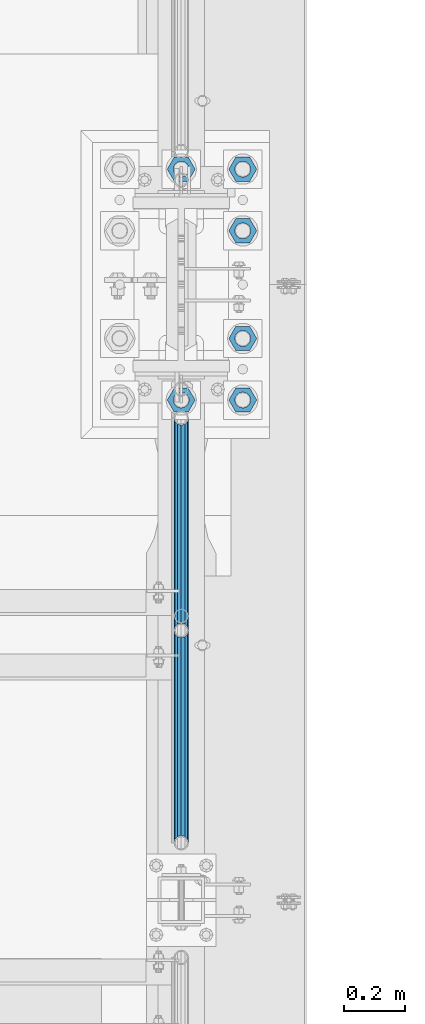
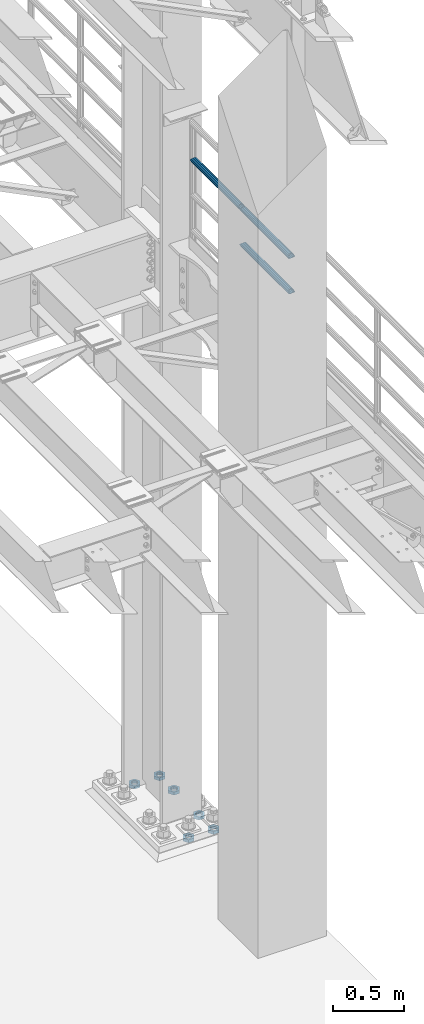
# One storey, part 1337 of 1876: 9 beams, 2 elements without a shape of their own.
"""IFC2X3 building model written with IfcOpenShell, lengths in millimetres."""

from ifc_helpers import new_model, si_unit, frame, origin_with_axes, place, context, subcontext, project, spatial, faceted_brep, material, type_object, element, aggregate, save


model = new_model("IFC2X3")

# Units and contexts
model_context = context("Model", 3, precision=1e-05, world=origin_with_axes())
body_context = subcontext(model_context, "Body", "Model", "MODEL_VIEW")
ifc_project = project(units=[si_unit("LENGTHUNIT", "METRE", prefix="MILLI"), si_unit("AREAUNIT", "SQUARE_METRE"), si_unit("VOLUMEUNIT", "CUBIC_METRE"), si_unit("MASSUNIT", "GRAM", prefix="KILO"), si_unit("TIMEUNIT", "SECOND"), si_unit("PLANEANGLEUNIT", "RADIAN"), si_unit("SOLIDANGLEUNIT", "STERADIAN"), si_unit("THERMODYNAMICTEMPERATUREUNIT", "DEGREE_CELSIUS"), si_unit("LUMINOUSINTENSITYUNIT", "LUMEN")], contexts=[model_context])

# Site, building, storey
site_placement = place(None, origin_with_axes())
site = spatial("IfcSite", under=ifc_project, at=site_placement, CompositionType="ELEMENT")
building_placement = place(site_placement, origin_with_axes())
building = spatial("IfcBuilding", under=site, at=building_placement, Name="Undefined", CompositionType="ELEMENT")
storey_placement = place(building_placement, origin_with_axes())
storey = spatial("IfcBuildingStorey", under=building, at=storey_placement, Name="Undefined", CompositionType="ELEMENT", Elevation=0.0)

# Assembly, beams
assembly_1_placement = place(storey_placement, origin_with_axes())
assembly_1 = element("IfcElementAssembly", 1, at=assembly_1_placement, inside=storey, Name="RAIL", AssemblyPlace="NOTDEFINED", PredefinedType="RIGID_FRAME")
ifc_material_1 = material()
beam_type_1 = type_object("IfcBeamType", Name="PIPE1-1/2SCH40", PredefinedType="NOTDEFINED")
beam_1_placement = place(assembly_1_placement, frame((7620.00000000007, 6478.5698316807, 5597.53091229414), z_axis=(0.0, 7.91400000045761e-06, -0.999999999968684), x_axis=(0.0, -0.999999999968684, -7.91400000071008e-06)))
beam_1 = element("IfcBeam", 2, at=beam_1_placement, type_object=beam_type_1, material=ifc_material_1, Name="RAIL", ObjectType="PIPE1-1/2SCH40", context=body_context, shape_type="Brep", body=[
    faceted_brep([(0.0, 24.1299999999992, 0.0), (12.0648982924813, 20.8971929933186, -12.0650000000005), (12.065101708381, 20.8971929933186, 12.0650000000005), (12.065101708381, -20.8971929933186, 12.0650000000005), (12.0648982924813, -20.8971929933186, -12.0650000000005), (0.0, -24.1299999999992, 0.0), (20.897369157401, -12.0649999999996, 20.8971929933205), (20.8973267454676, -12.0649999999277, 15.8661214312533), (15.2546577467156, -17.7076214311801, 10.223500000001), (12.5151929933249, -20.4470000000001, 0.0), (15.2544853785057, -17.7076214311801, -10.2235000000001), (20.8970592426604, -12.0649999999277, -15.8661214312533), (20.8970168307269, -12.0649999999996, -20.8971929933195), (24.1298276326506, 0.0, -20.447000000001), (24.1297965849608, 0.0, -24.130000000001), (21.390472156676, -10.2235000000001, -17.7076214311819), (21.3904721567151, 10.2235000000001, -17.7076214311819), (20.8970592426604, 12.0650000000714, -15.8661214311096), (20.8970168307269, 12.0649999999996, -20.8971929933195), (15.2544853786503, 17.7076214311801, -10.2235000000001), (12.5151929933249, 20.4470000000001, 0.0), (15.2546577468602, 17.7076214311801, 10.223500000001), (20.8973267454676, 12.0650000000714, 15.8661214311096), (20.897369157401, 12.0649999999996, 20.8971929933205), (21.3907707072121, 10.2235000000001, 17.7076214311819), (24.1301723690713, 7.18500814400613e-11, 20.447000000001), (24.1302034167611, 7.18500814400613e-11, 24.1300000000019), (21.390770707173, -10.2235000000001, 17.7076214311819), (701.33983170571, 24.1300000000001, -1.45519152283669e-11), (689.27472999733, 20.8971929933186, -12.0650000000151), (680.442462548309, 12.0649999999996, -20.8971929933323), (701.33983170571, -24.1299999999283, -1.45519152283669e-11), (689.27472999733, -20.8971929933186, -12.0650000000151), (689.27493341323, -20.8971929933186, 12.0649999999878), (680.442814874983, -12.0649999999996, 20.8971929933068), (680.442462548309, -12.0649999999996, -20.8971929933323), (677.20962828895, 0.0, -24.1300000000147), (679.949060998498, 10.2235000000001, -17.7076214311946), (677.20965933664, 0.0, -20.4470000000147), (680.442504960242, 12.0650000000714, -15.8661214311223), (680.442504960242, -12.0649999999277, -15.866121431266), (679.949060998536, -10.2235000000001, -17.7076214311946), (686.085173958994, -17.7076214311801, -10.2235000000137), (688.824638712016, -20.4470000000001, -1.36424205265939e-11), (686.085346327204, -17.7076214311801, 10.2234999999873), (680.44277246305, -12.0649999999277, 15.8661214312397), (679.949359549034, -10.2235000000001, 17.7076214311674), (677.210004073059, 2.72848410531878e-12, 20.4469999999883), (677.210035120749, 2.72848410531878e-12, 24.1299999999883), (680.442814874983, 12.0649999999996, 20.8971929933068), (689.27493341323, 20.8971929933186, 12.0649999999878), (680.44277246305, 12.0650000000714, 15.866121431096), (686.085346327061, 17.7076214311801, 10.2234999999873), (688.824638711873, 20.4470000000001, -1.36424205265939e-11), (686.085173958852, 17.7076214311801, -10.2235000000137), (679.949359548996, 10.2235000000001, 17.7076214311674)], [[[0, 1, 2]], [[3, 4, 5]], [[6, 7, 8, 9, 10, 11, 12, 4, 3]], [[13, 14, 12, 11, 15]], [[16, 17, 18, 14, 13]], [[2, 1, 18, 17, 19, 20, 21, 22, 23]], [[23, 22, 24, 25, 26]], [[26, 25, 27, 7, 6]], [[1, 0, 28, 29]], [[18, 1, 29, 30]], [[31, 32, 33]], [[6, 3, 33, 34]], [[3, 5, 31, 33]], [[5, 4, 32, 31]], [[4, 12, 35, 32]], [[12, 14, 36, 35]], [[14, 18, 30, 36]], [[37, 38, 36, 30, 39]], [[40, 35, 36, 38, 41]], [[33, 32, 35, 40, 42, 43, 44, 45, 34]], [[34, 45, 46, 47, 48]], [[26, 6, 34, 48]], [[2, 23, 49, 50]], [[23, 26, 48, 49]], [[0, 2, 50, 28]], [[28, 50, 29]], [[49, 51, 52, 53, 54, 39, 30, 29, 50]], [[48, 47, 55, 51, 49]], [[25, 24, 55, 47]], [[55, 24, 22, 21, 52, 51]], [[21, 20, 53, 52]], [[20, 19, 54, 53]], [[19, 17, 16, 37, 39, 54]], [[16, 13, 38, 37]], [[13, 15, 41, 38]], [[41, 15, 11, 10, 42, 40]], [[10, 9, 43, 42]], [[9, 8, 44, 43]], [[8, 7, 27, 46, 45, 44]], [[27, 25, 47, 46]]]),
])
beam_2_placement = place(assembly_1_placement, frame((7620.00000000067, 7179.9096633614, 5902.3368245991), z_axis=(0.0, 7.91400000045761e-06, -0.999999999968684), x_axis=(0.0, -0.999999999968684, -7.91400000071008e-06)))
beam_2 = element("IfcBeam", 3, at=beam_2_placement, type_object=beam_type_1, material=ifc_material_1, Name="RAIL", ObjectType="PIPE1-1/2SCH40", context=body_context, shape_type="Brep", body=[
    faceted_brep([(0.0, 24.1299999999992, 0.0), (12.0648982924813, 20.8971929933186, -12.0650000000005), (12.065101708381, 20.8971929933186, 12.0650000000005), (12.065101708381, -20.8971929933186, 12.0650000000005), (12.0648982924813, -20.8971929933186, -12.0650000000005), (0.0, -24.1299999999992, 0.0), (20.897369157401, -12.0649999999996, 20.8971929933205), (20.8973267454676, -12.0649999999277, 15.8661214312533), (15.2546577467156, -17.7076214311801, 10.223500000001), (12.5151929933249, -20.4470000000001, 0.0), (15.2544853785057, -17.7076214311801, -10.2235000000001), (20.8970592426604, -12.0649999999277, -15.8661214312533), (20.8970168307269, -12.0649999999996, -20.8971929933195), (24.1298276326506, 0.0, -20.447000000001), (24.1297965849608, 0.0, -24.130000000001), (21.390472156676, -10.2235000000001, -17.7076214311819), (21.3904721567151, 10.2235000000001, -17.7076214311819), (20.8970592426604, 12.0650000000714, -15.8661214311096), (20.8970168307269, 12.0649999999996, -20.8971929933195), (15.2544853786503, 17.7076214311801, -10.2235000000001), (12.5151929933249, 20.4470000000001, 0.0), (15.2546577468602, 17.7076214311801, 10.223500000001), (20.8973267454676, 12.0650000000714, 15.8661214311096), (20.897369157401, 12.0649999999996, 20.8971929933205), (21.3907707072121, 10.2235000000001, 17.7076214311819), (24.1301723690713, 7.18500814400613e-11, 20.447000000001), (24.1302034167611, 7.18500814400613e-11, 24.1300000000019), (21.390770707173, -10.2235000000001, 17.7076214311819), (701.33983170571, 24.1300000000001, -1.45519152283669e-11), (689.27472999733, 20.8971929933186, -12.0650000000151), (680.442462548309, 12.0649999999996, -20.8971929933323), (701.33983170571, -24.1299999999283, -1.45519152283669e-11), (689.27472999733, -20.8971929933186, -12.0650000000151), (689.27493341323, -20.8971929933186, 12.0649999999878), (680.442814874983, -12.0649999999996, 20.8971929933068), (680.442462548309, -12.0649999999996, -20.8971929933323), (677.20962828895, 0.0, -24.1300000000147), (679.949060998498, 10.2235000000001, -17.7076214311946), (677.20965933664, 0.0, -20.4470000000147), (680.442504960242, 12.0650000000714, -15.8661214311223), (680.442504960242, -12.0649999999277, -15.866121431266), (679.949060998536, -10.2235000000001, -17.7076214311946), (686.085173958994, -17.7076214311801, -10.2235000000137), (688.824638712016, -20.4470000000001, -1.36424205265939e-11), (686.085346327204, -17.7076214311801, 10.2234999999873), (680.44277246305, -12.0649999999277, 15.8661214312397), (679.949359549034, -10.2235000000001, 17.7076214311674), (677.210004073059, 2.72848410531878e-12, 20.4469999999883), (677.210035120749, 2.72848410531878e-12, 24.1299999999883), (680.442814874983, 12.0649999999996, 20.8971929933068), (689.27493341323, 20.8971929933186, 12.0649999999878), (680.44277246305, 12.0650000000714, 15.866121431096), (686.085346327061, 17.7076214311801, 10.2234999999873), (688.824638711873, 20.4470000000001, -1.36424205265939e-11), (686.085173958852, 17.7076214311801, -10.2235000000137), (679.949359548996, 10.2235000000001, 17.7076214311674)], [[[0, 1, 2]], [[3, 4, 5]], [[6, 7, 8, 9, 10, 11, 12, 4, 3]], [[13, 14, 12, 11, 15]], [[16, 17, 18, 14, 13]], [[2, 1, 18, 17, 19, 20, 21, 22, 23]], [[23, 22, 24, 25, 26]], [[26, 25, 27, 7, 6]], [[1, 0, 28, 29]], [[18, 1, 29, 30]], [[31, 32, 33]], [[6, 3, 33, 34]], [[3, 5, 31, 33]], [[5, 4, 32, 31]], [[4, 12, 35, 32]], [[12, 14, 36, 35]], [[14, 18, 30, 36]], [[37, 38, 36, 30, 39]], [[40, 35, 36, 38, 41]], [[33, 32, 35, 40, 42, 43, 44, 45, 34]], [[34, 45, 46, 47, 48]], [[26, 6, 34, 48]], [[2, 23, 49, 50]], [[23, 26, 48, 49]], [[0, 2, 50, 28]], [[28, 50, 29]], [[49, 51, 52, 53, 54, 39, 30, 29, 50]], [[48, 47, 55, 51, 49]], [[25, 24, 55, 47]], [[55, 24, 22, 21, 52, 51]], [[21, 20, 53, 52]], [[20, 19, 54, 53]], [[19, 17, 16, 37, 39, 54]], [[16, 13, 38, 37]], [[13, 15, 41, 38]], [[41, 15, 11, 10, 42, 40]], [[10, 9, 43, 42]], [[9, 8, 44, 43]], [[8, 7, 27, 46, 45, 44]], [[27, 25, 47, 46]]]),
])
beam_3_placement = place(assembly_1_placement, frame((7620.00000000007, 6478.5698316807, 5902.33091229485), z_axis=(0.0, 7.91400000045761e-06, -0.999999999968684), x_axis=(0.0, -0.999999999968684, -7.91400000071008e-06)))
beam_3 = element("IfcBeam", 4, at=beam_3_placement, type_object=beam_type_1, material=ifc_material_1, Name="RAIL", ObjectType="PIPE1-1/2SCH40", context=body_context, shape_type="Brep", body=[
    faceted_brep([(0.0, 24.1299999999992, 0.0), (12.0648982924813, 20.8971929933186, -12.0650000000005), (12.065101708381, 20.8971929933186, 12.0650000000005), (12.065101708381, -20.8971929933186, 12.0650000000005), (12.0648982924813, -20.8971929933186, -12.0650000000005), (0.0, -24.1299999999992, 0.0), (20.897369157401, -12.0649999999996, 20.8971929933205), (20.8973267454676, -12.0649999999277, 15.8661214312533), (15.2546577467156, -17.7076214311801, 10.223500000001), (12.5151929933249, -20.4470000000001, 0.0), (15.2544853785057, -17.7076214311801, -10.2235000000001), (20.8970592426604, -12.0649999999277, -15.8661214312533), (20.8970168307269, -12.0649999999996, -20.8971929933195), (24.1298276326506, 0.0, -20.447000000001), (24.1297965849608, 0.0, -24.130000000001), (21.390472156676, -10.2235000000001, -17.7076214311819), (21.3904721567151, 10.2235000000001, -17.7076214311819), (20.8970592426604, 12.0650000000714, -15.8661214311096), (20.8970168307269, 12.0649999999996, -20.8971929933195), (15.2544853786503, 17.7076214311801, -10.2235000000001), (12.5151929933249, 20.4470000000001, 0.0), (15.2546577468602, 17.7076214311801, 10.223500000001), (20.8973267454676, 12.0650000000714, 15.8661214311096), (20.897369157401, 12.0649999999996, 20.8971929933205), (21.3907707072121, 10.2235000000001, 17.7076214311819), (24.1301723690713, 7.18500814400613e-11, 20.447000000001), (24.1302034167611, 7.18500814400613e-11, 24.1300000000019), (21.390770707173, -10.2235000000001, 17.7076214311819), (701.33983170571, 24.1300000000001, -1.45519152283669e-11), (689.27472999733, 20.8971929933186, -12.0650000000151), (680.442462548309, 12.0649999999996, -20.8971929933323), (701.33983170571, -24.1299999999283, -1.45519152283669e-11), (689.27472999733, -20.8971929933186, -12.0650000000151), (689.27493341323, -20.8971929933186, 12.0649999999878), (680.442814874983, -12.0649999999996, 20.8971929933068), (680.442462548309, -12.0649999999996, -20.8971929933323), (677.20962828895, 0.0, -24.1300000000147), (679.949060998498, 10.2235000000001, -17.7076214311946), (677.20965933664, 0.0, -20.4470000000147), (680.442504960242, 12.0650000000714, -15.8661214311223), (680.442504960242, -12.0649999999277, -15.866121431266), (679.949060998536, -10.2235000000001, -17.7076214311946), (686.085173958994, -17.7076214311801, -10.2235000000137), (688.824638712016, -20.4470000000001, -1.36424205265939e-11), (686.085346327204, -17.7076214311801, 10.2234999999873), (680.44277246305, -12.0649999999277, 15.8661214312397), (679.949359549034, -10.2235000000001, 17.7076214311674), (677.210004073059, 2.72848410531878e-12, 20.4469999999883), (677.210035120749, 2.72848410531878e-12, 24.1299999999883), (680.442814874983, 12.0649999999996, 20.8971929933068), (689.27493341323, 20.8971929933186, 12.0649999999878), (680.44277246305, 12.0650000000714, 15.866121431096), (686.085346327061, 17.7076214311801, 10.2234999999873), (688.824638711873, 20.4470000000001, -1.36424205265939e-11), (686.085173958852, 17.7076214311801, -10.2235000000137), (679.949359548996, 10.2235000000001, 17.7076214311674)], [[[0, 1, 2]], [[3, 4, 5]], [[6, 7, 8, 9, 10, 11, 12, 4, 3]], [[13, 14, 12, 11, 15]], [[16, 17, 18, 14, 13]], [[2, 1, 18, 17, 19, 20, 21, 22, 23]], [[23, 22, 24, 25, 26]], [[26, 25, 27, 7, 6]], [[1, 0, 28, 29]], [[18, 1, 29, 30]], [[31, 32, 33]], [[6, 3, 33, 34]], [[3, 5, 31, 33]], [[5, 4, 32, 31]], [[4, 12, 35, 32]], [[12, 14, 36, 35]], [[14, 18, 30, 36]], [[37, 38, 36, 30, 39]], [[40, 35, 36, 38, 41]], [[33, 32, 35, 40, 42, 43, 44, 45, 34]], [[34, 45, 46, 47, 48]], [[26, 6, 34, 48]], [[2, 23, 49, 50]], [[23, 26, 48, 49]], [[0, 2, 50, 28]], [[28, 50, 29]], [[49, 51, 52, 53, 54, 39, 30, 29, 50]], [[48, 47, 55, 51, 49]], [[25, 24, 55, 47]], [[55, 24, 22, 21, 52, 51]], [[21, 20, 53, 52]], [[20, 19, 54, 53]], [[19, 17, 16, 37, 39, 54]], [[16, 13, 38, 37]], [[13, 15, 41, 38]], [[41, 15, 11, 10, 42, 40]], [[10, 9, 43, 42]], [[9, 8, 44, 43]], [[8, 7, 27, 46, 45, 44]], [[27, 25, 47, 46]]]),
])
aggregate(assembly_1, [beam_1, beam_2, beam_3])

assembly_2_placement = place(storey_placement, origin_with_axes())
assembly_2 = element("IfcElementAssembly", 5, at=assembly_2_placement, inside=storey, Name="TEMPLATE", AssemblyPlace="NOTDEFINED", PredefinedType="RIGID_FRAME")
ifc_material_2 = material(Name="STEEL/A563")
beam_type_2 = type_object("IfcBeamType", Name="2_DIA. HALF_NUT", PredefinedType="NOTDEFINED")
beam_4_placement = place(assembly_2_placement, frame((7620.0, 8000.99999847412, 33.3375), z_axis=(0.0, -1.0, 0.0), x_axis=(0.0, 0.0, -1.0)))
beam_4 = element("IfcBeam", 6, at=beam_4_placement, type_object=beam_type_2, material=ifc_material_2, Name="NUT", ObjectType="2_DIA. HALF_NUT", context=body_context, shape_type="Brep", body=[
    faceted_brep([(0.0, -46.0369987487793, 9.09494701772928e-13), (0.0, -23.0184993743896, -39.869213104248), (25.4, -23.0184993743896, -39.869213104248), (25.4, -46.0369987487793, 9.09494701772928e-13), (0.0, 23.0184993743896, -39.869213104248), (25.4, 23.0184993743896, -39.869213104248), (0.0, 46.0369987487793, -9.09494701772928e-13), (25.4, 46.0369987487793, -9.09494701772928e-13), (0.0, 23.0184993743896, 39.869213104248), (25.4, 23.0184993743896, 39.869213104248), (0.0, -23.0184993743896, 39.869213104248), (25.4, -23.0184993743896, 39.869213104248), (0.0, 0.0, 26.1940002441406), (0.0, 11.3650617044514, 23.5999013092769), (25.4, 11.3650617044514, 23.5999013092769), (25.4, 0.0, 26.1940002441406), (0.0, 20.4791109456437, 16.3316083006703), (25.4, 20.4791109456437, 16.3316083006703), (0.0, 25.5370200498346, 5.82867859874477), (25.4, 25.5370200498346, 5.82867859874477), (0.0, 25.5370200498346, -5.82867859874477), (25.4, 25.5370200498346, -5.82867859874477), (0.0, 20.4791109456437, -16.3316083006703), (25.4, 20.4791109456437, -16.3316083006703), (0.0, 11.3650617044514, -23.5999013092769), (25.4, 11.3650617044514, -23.5999013092769), (0.0, 0.0, -26.1940002441406), (25.4, 0.0, -26.1940002441406), (0.0, -11.3650617044514, -23.5999013092769), (25.4, -11.3650617044514, -23.5999013092769), (0.0, -20.4791109456437, -16.3316083006703), (25.4, -20.4791109456437, -16.3316083006703), (0.0, -25.5370200498346, -5.82867859874477), (25.4, -25.5370200498346, -5.82867859874477), (0.0, -25.5370200498346, 5.82867859874477), (25.4, -25.5370200498346, 5.82867859874477), (0.0, -20.4791109456437, 16.3316083006703), (25.4, -20.4791109456437, 16.3316083006703), (0.0, -11.3650617044514, 23.5999013092769), (25.4, -11.3650617044514, 23.5999013092769)], [[[0, 1, 2, 3]], [[1, 4, 5, 2]], [[4, 6, 7, 5]], [[6, 8, 9, 7]], [[8, 10, 11, 9]], [[10, 0, 3, 11]], [[12, 13, 14, 15]], [[13, 16, 17, 14]], [[16, 18, 19, 17]], [[18, 20, 21, 19]], [[20, 22, 23, 21]], [[22, 24, 25, 23]], [[24, 26, 27, 25]], [[26, 28, 29, 27]], [[28, 30, 31, 29]], [[30, 32, 33, 31]], [[32, 34, 35, 33]], [[34, 36, 37, 35]], [[36, 38, 39, 37]], [[38, 12, 15, 39]], [[5, 7, 9, 11, 3, 2], [17, 19, 21, 23, 25, 27, 29, 31, 33, 35, 37, 39, 15, 14]], [[10, 8, 6, 4, 1, 0], [38, 36, 34, 32, 30, 28, 26, 24, 22, 20, 18, 16, 13, 12]]]),
])
beam_5_placement = place(assembly_2_placement, frame((7823.2, 8001.00000152588, 33.3375), z_axis=(0.0, 1.0, 0.0), x_axis=(0.0, 0.0, -1.0)))
beam_5 = element("IfcBeam", 7, at=beam_5_placement, type_object=beam_type_2, material=ifc_material_2, Name="NUT", ObjectType="2_DIA. HALF_NUT", context=body_context, shape_type="Brep", body=[
    faceted_brep([(0.0, -46.0369987487793, 9.09494701772928e-13), (0.0, -23.0184993743896, -39.869213104248), (25.4, -23.0184993743896, -39.869213104248), (25.4, -46.0369987487793, 9.09494701772928e-13), (0.0, 23.0184993743896, -39.869213104248), (25.4, 23.0184993743896, -39.869213104248), (0.0, 46.0369987487793, -9.09494701772928e-13), (25.4, 46.0369987487793, -9.09494701772928e-13), (0.0, 23.0184993743896, 39.869213104248), (25.4, 23.0184993743896, 39.869213104248), (0.0, -23.0184993743896, 39.869213104248), (25.4, -23.0184993743896, 39.869213104248), (0.0, 0.0, 26.1940002441406), (0.0, 11.3650617044514, 23.5999013092769), (25.4, 11.3650617044514, 23.5999013092769), (25.4, 0.0, 26.1940002441406), (0.0, 20.4791109456437, 16.3316083006703), (25.4, 20.4791109456437, 16.3316083006703), (0.0, 25.5370200498346, 5.82867859874477), (25.4, 25.5370200498346, 5.82867859874477), (0.0, 25.5370200498346, -5.82867859874477), (25.4, 25.5370200498346, -5.82867859874477), (0.0, 20.4791109456437, -16.3316083006703), (25.4, 20.4791109456437, -16.3316083006703), (0.0, 11.3650617044514, -23.5999013092769), (25.4, 11.3650617044514, -23.5999013092769), (0.0, 0.0, -26.1940002441406), (25.4, 0.0, -26.1940002441406), (0.0, -11.3650617044514, -23.5999013092769), (25.4, -11.3650617044514, -23.5999013092769), (0.0, -20.4791109456437, -16.3316083006703), (25.4, -20.4791109456437, -16.3316083006703), (0.0, -25.5370200498346, -5.82867859874477), (25.4, -25.5370200498346, -5.82867859874477), (0.0, -25.5370200498346, 5.82867859874477), (25.4, -25.5370200498346, 5.82867859874477), (0.0, -20.4791109456437, 16.3316083006703), (25.4, -20.4791109456437, 16.3316083006703), (0.0, -11.3650617044514, 23.5999013092769), (25.4, -11.3650617044514, 23.5999013092769)], [[[0, 1, 2, 3]], [[1, 4, 5, 2]], [[4, 6, 7, 5]], [[6, 8, 9, 7]], [[8, 10, 11, 9]], [[10, 0, 3, 11]], [[12, 13, 14, 15]], [[13, 16, 17, 14]], [[16, 18, 19, 17]], [[18, 20, 21, 19]], [[20, 22, 23, 21]], [[22, 24, 25, 23]], [[24, 26, 27, 25]], [[26, 28, 29, 27]], [[28, 30, 31, 29]], [[30, 32, 33, 31]], [[32, 34, 35, 33]], [[34, 36, 37, 35]], [[36, 38, 39, 37]], [[38, 12, 15, 39]], [[5, 7, 9, 11, 3, 2], [17, 19, 21, 23, 25, 27, 29, 31, 33, 35, 37, 39, 15, 14]], [[10, 8, 6, 4, 1, 0], [38, 36, 34, 32, 30, 28, 26, 24, 22, 20, 18, 16, 13, 12]]]),
])
beam_6_placement = place(assembly_2_placement, frame((7823.2, 7797.80000152588, 33.3375), z_axis=(0.0, 1.0, 0.0), x_axis=(0.0, 0.0, -1.0)))
beam_6 = element("IfcBeam", 8, at=beam_6_placement, type_object=beam_type_2, material=ifc_material_2, Name="NUT", ObjectType="2_DIA. HALF_NUT", context=body_context, shape_type="Brep", body=[
    faceted_brep([(0.0, -46.0369987487793, 9.09494701772928e-13), (0.0, -23.0184993743896, -39.869213104248), (25.4, -23.0184993743896, -39.869213104248), (25.4, -46.0369987487793, 9.09494701772928e-13), (0.0, 23.0184993743896, -39.869213104248), (25.4, 23.0184993743896, -39.869213104248), (0.0, 46.0369987487793, -9.09494701772928e-13), (25.4, 46.0369987487793, -9.09494701772928e-13), (0.0, 23.0184993743896, 39.869213104248), (25.4, 23.0184993743896, 39.869213104248), (0.0, -23.0184993743896, 39.869213104248), (25.4, -23.0184993743896, 39.869213104248), (0.0, 0.0, 26.1940002441406), (0.0, 11.3650617044514, 23.5999013092769), (25.4, 11.3650617044514, 23.5999013092769), (25.4, 0.0, 26.1940002441406), (0.0, 20.4791109456437, 16.3316083006703), (25.4, 20.4791109456437, 16.3316083006703), (0.0, 25.5370200498346, 5.82867859874477), (25.4, 25.5370200498346, 5.82867859874477), (0.0, 25.5370200498346, -5.82867859874477), (25.4, 25.5370200498346, -5.82867859874477), (0.0, 20.4791109456437, -16.3316083006703), (25.4, 20.4791109456437, -16.3316083006703), (0.0, 11.3650617044514, -23.5999013092769), (25.4, 11.3650617044514, -23.5999013092769), (0.0, 0.0, -26.1940002441406), (25.4, 0.0, -26.1940002441406), (0.0, -11.3650617044514, -23.5999013092769), (25.4, -11.3650617044514, -23.5999013092769), (0.0, -20.4791109456437, -16.3316083006703), (25.4, -20.4791109456437, -16.3316083006703), (0.0, -25.5370200498346, -5.82867859874477), (25.4, -25.5370200498346, -5.82867859874477), (0.0, -25.5370200498346, 5.82867859874477), (25.4, -25.5370200498346, 5.82867859874477), (0.0, -20.4791109456437, 16.3316083006703), (25.4, -20.4791109456437, 16.3316083006703), (0.0, -11.3650617044514, 23.5999013092769), (25.4, -11.3650617044514, 23.5999013092769)], [[[0, 1, 2, 3]], [[1, 4, 5, 2]], [[4, 6, 7, 5]], [[6, 8, 9, 7]], [[8, 10, 11, 9]], [[10, 0, 3, 11]], [[12, 13, 14, 15]], [[13, 16, 17, 14]], [[16, 18, 19, 17]], [[18, 20, 21, 19]], [[20, 22, 23, 21]], [[22, 24, 25, 23]], [[24, 26, 27, 25]], [[26, 28, 29, 27]], [[28, 30, 31, 29]], [[30, 32, 33, 31]], [[32, 34, 35, 33]], [[34, 36, 37, 35]], [[36, 38, 39, 37]], [[38, 12, 15, 39]], [[5, 7, 9, 11, 3, 2], [17, 19, 21, 23, 25, 27, 29, 31, 33, 35, 37, 39, 15, 14]], [[10, 8, 6, 4, 1, 0], [38, 36, 34, 32, 30, 28, 26, 24, 22, 20, 18, 16, 13, 12]]]),
])
beam_7_placement = place(assembly_2_placement, frame((7823.2, 7442.20000152588, 33.3375), z_axis=(0.0, 1.0, 0.0), x_axis=(0.0, 0.0, -1.0)))
beam_7 = element("IfcBeam", 9, at=beam_7_placement, type_object=beam_type_2, material=ifc_material_2, Name="NUT", ObjectType="2_DIA. HALF_NUT", context=body_context, shape_type="Brep", body=[
    faceted_brep([(0.0, -46.0369987487793, 9.09494701772928e-13), (0.0, -23.0184993743896, -39.869213104248), (25.4, -23.0184993743896, -39.869213104248), (25.4, -46.0369987487793, 9.09494701772928e-13), (0.0, 23.0184993743896, -39.869213104248), (25.4, 23.0184993743896, -39.869213104248), (0.0, 46.0369987487793, -9.09494701772928e-13), (25.4, 46.0369987487793, -9.09494701772928e-13), (0.0, 23.0184993743896, 39.869213104248), (25.4, 23.0184993743896, 39.869213104248), (0.0, -23.0184993743896, 39.869213104248), (25.4, -23.0184993743896, 39.869213104248), (0.0, 0.0, 26.1940002441406), (0.0, 11.3650617044514, 23.5999013092769), (25.4, 11.3650617044514, 23.5999013092769), (25.4, 0.0, 26.1940002441406), (0.0, 20.4791109456437, 16.3316083006703), (25.4, 20.4791109456437, 16.3316083006703), (0.0, 25.5370200498346, 5.82867859874477), (25.4, 25.5370200498346, 5.82867859874477), (0.0, 25.5370200498346, -5.82867859874477), (25.4, 25.5370200498346, -5.82867859874477), (0.0, 20.4791109456437, -16.3316083006703), (25.4, 20.4791109456437, -16.3316083006703), (0.0, 11.3650617044514, -23.5999013092769), (25.4, 11.3650617044514, -23.5999013092769), (0.0, 0.0, -26.1940002441406), (25.4, 0.0, -26.1940002441406), (0.0, -11.3650617044514, -23.5999013092769), (25.4, -11.3650617044514, -23.5999013092769), (0.0, -20.4791109456437, -16.3316083006703), (25.4, -20.4791109456437, -16.3316083006703), (0.0, -25.5370200498346, -5.82867859874477), (25.4, -25.5370200498346, -5.82867859874477), (0.0, -25.5370200498346, 5.82867859874477), (25.4, -25.5370200498346, 5.82867859874477), (0.0, -20.4791109456437, 16.3316083006703), (25.4, -20.4791109456437, 16.3316083006703), (0.0, -11.3650617044514, 23.5999013092769), (25.4, -11.3650617044514, 23.5999013092769)], [[[0, 1, 2, 3]], [[1, 4, 5, 2]], [[4, 6, 7, 5]], [[6, 8, 9, 7]], [[8, 10, 11, 9]], [[10, 0, 3, 11]], [[12, 13, 14, 15]], [[13, 16, 17, 14]], [[16, 18, 19, 17]], [[18, 20, 21, 19]], [[20, 22, 23, 21]], [[22, 24, 25, 23]], [[24, 26, 27, 25]], [[26, 28, 29, 27]], [[28, 30, 31, 29]], [[30, 32, 33, 31]], [[32, 34, 35, 33]], [[34, 36, 37, 35]], [[36, 38, 39, 37]], [[38, 12, 15, 39]], [[5, 7, 9, 11, 3, 2], [17, 19, 21, 23, 25, 27, 29, 31, 33, 35, 37, 39, 15, 14]], [[10, 8, 6, 4, 1, 0], [38, 36, 34, 32, 30, 28, 26, 24, 22, 20, 18, 16, 13, 12]]]),
])
beam_8_placement = place(assembly_2_placement, frame((7823.2, 7239.00000152588, 33.3375), z_axis=(0.0, 1.0, 0.0), x_axis=(0.0, 0.0, -1.0)))
beam_8 = element("IfcBeam", 10, at=beam_8_placement, type_object=beam_type_2, material=ifc_material_2, Name="NUT", ObjectType="2_DIA. HALF_NUT", context=body_context, shape_type="Brep", body=[
    faceted_brep([(0.0, -46.0369987487793, 9.09494701772928e-13), (0.0, -23.0184993743896, -39.869213104248), (25.4, -23.0184993743896, -39.869213104248), (25.4, -46.0369987487793, 9.09494701772928e-13), (0.0, 23.0184993743896, -39.869213104248), (25.4, 23.0184993743896, -39.869213104248), (0.0, 46.0369987487793, -9.09494701772928e-13), (25.4, 46.0369987487793, -9.09494701772928e-13), (0.0, 23.0184993743896, 39.869213104248), (25.4, 23.0184993743896, 39.869213104248), (0.0, -23.0184993743896, 39.869213104248), (25.4, -23.0184993743896, 39.869213104248), (0.0, 0.0, 26.1940002441406), (0.0, 11.3650617044514, 23.5999013092769), (25.4, 11.3650617044514, 23.5999013092769), (25.4, 0.0, 26.1940002441406), (0.0, 20.4791109456437, 16.3316083006703), (25.4, 20.4791109456437, 16.3316083006703), (0.0, 25.5370200498346, 5.82867859874477), (25.4, 25.5370200498346, 5.82867859874477), (0.0, 25.5370200498346, -5.82867859874477), (25.4, 25.5370200498346, -5.82867859874477), (0.0, 20.4791109456437, -16.3316083006703), (25.4, 20.4791109456437, -16.3316083006703), (0.0, 11.3650617044514, -23.5999013092769), (25.4, 11.3650617044514, -23.5999013092769), (0.0, 0.0, -26.1940002441406), (25.4, 0.0, -26.1940002441406), (0.0, -11.3650617044514, -23.5999013092769), (25.4, -11.3650617044514, -23.5999013092769), (0.0, -20.4791109456437, -16.3316083006703), (25.4, -20.4791109456437, -16.3316083006703), (0.0, -25.5370200498346, -5.82867859874477), (25.4, -25.5370200498346, -5.82867859874477), (0.0, -25.5370200498346, 5.82867859874477), (25.4, -25.5370200498346, 5.82867859874477), (0.0, -20.4791109456437, 16.3316083006703), (25.4, -20.4791109456437, 16.3316083006703), (0.0, -11.3650617044514, 23.5999013092769), (25.4, -11.3650617044514, 23.5999013092769)], [[[0, 1, 2, 3]], [[1, 4, 5, 2]], [[4, 6, 7, 5]], [[6, 8, 9, 7]], [[8, 10, 11, 9]], [[10, 0, 3, 11]], [[12, 13, 14, 15]], [[13, 16, 17, 14]], [[16, 18, 19, 17]], [[18, 20, 21, 19]], [[20, 22, 23, 21]], [[22, 24, 25, 23]], [[24, 26, 27, 25]], [[26, 28, 29, 27]], [[28, 30, 31, 29]], [[30, 32, 33, 31]], [[32, 34, 35, 33]], [[34, 36, 37, 35]], [[36, 38, 39, 37]], [[38, 12, 15, 39]], [[5, 7, 9, 11, 3, 2], [17, 19, 21, 23, 25, 27, 29, 31, 33, 35, 37, 39, 15, 14]], [[10, 8, 6, 4, 1, 0], [38, 36, 34, 32, 30, 28, 26, 24, 22, 20, 18, 16, 13, 12]]]),
])
beam_9_placement = place(assembly_2_placement, frame((7620.0, 7238.99999847412, 33.3375), z_axis=(0.0, -1.0, 0.0), x_axis=(0.0, 0.0, -1.0)))
beam_9 = element("IfcBeam", 11, at=beam_9_placement, type_object=beam_type_2, material=ifc_material_2, Name="NUT", ObjectType="2_DIA. HALF_NUT", context=body_context, shape_type="Brep", body=[
    faceted_brep([(0.0, -46.0369987487793, 9.09494701772928e-13), (0.0, -23.0184993743896, -39.869213104248), (25.4, -23.0184993743896, -39.869213104248), (25.4, -46.0369987487793, 9.09494701772928e-13), (0.0, 23.0184993743896, -39.869213104248), (25.4, 23.0184993743896, -39.869213104248), (0.0, 46.0369987487793, -9.09494701772928e-13), (25.4, 46.0369987487793, -9.09494701772928e-13), (0.0, 23.0184993743896, 39.869213104248), (25.4, 23.0184993743896, 39.869213104248), (0.0, -23.0184993743896, 39.869213104248), (25.4, -23.0184993743896, 39.869213104248), (0.0, 0.0, 26.1940002441406), (0.0, 11.3650617044514, 23.5999013092769), (25.4, 11.3650617044514, 23.5999013092769), (25.4, 0.0, 26.1940002441406), (0.0, 20.4791109456437, 16.3316083006703), (25.4, 20.4791109456437, 16.3316083006703), (0.0, 25.5370200498346, 5.82867859874477), (25.4, 25.5370200498346, 5.82867859874477), (0.0, 25.5370200498346, -5.82867859874477), (25.4, 25.5370200498346, -5.82867859874477), (0.0, 20.4791109456437, -16.3316083006703), (25.4, 20.4791109456437, -16.3316083006703), (0.0, 11.3650617044514, -23.5999013092769), (25.4, 11.3650617044514, -23.5999013092769), (0.0, 0.0, -26.1940002441406), (25.4, 0.0, -26.1940002441406), (0.0, -11.3650617044514, -23.5999013092769), (25.4, -11.3650617044514, -23.5999013092769), (0.0, -20.4791109456437, -16.3316083006703), (25.4, -20.4791109456437, -16.3316083006703), (0.0, -25.5370200498346, -5.82867859874477), (25.4, -25.5370200498346, -5.82867859874477), (0.0, -25.5370200498346, 5.82867859874477), (25.4, -25.5370200498346, 5.82867859874477), (0.0, -20.4791109456437, 16.3316083006703), (25.4, -20.4791109456437, 16.3316083006703), (0.0, -11.3650617044514, 23.5999013092769), (25.4, -11.3650617044514, 23.5999013092769)], [[[0, 1, 2, 3]], [[1, 4, 5, 2]], [[4, 6, 7, 5]], [[6, 8, 9, 7]], [[8, 10, 11, 9]], [[10, 0, 3, 11]], [[12, 13, 14, 15]], [[13, 16, 17, 14]], [[16, 18, 19, 17]], [[18, 20, 21, 19]], [[20, 22, 23, 21]], [[22, 24, 25, 23]], [[24, 26, 27, 25]], [[26, 28, 29, 27]], [[28, 30, 31, 29]], [[30, 32, 33, 31]], [[32, 34, 35, 33]], [[34, 36, 37, 35]], [[36, 38, 39, 37]], [[38, 12, 15, 39]], [[5, 7, 9, 11, 3, 2], [17, 19, 21, 23, 25, 27, 29, 31, 33, 35, 37, 39, 15, 14]], [[10, 8, 6, 4, 1, 0], [38, 36, 34, 32, 30, 28, 26, 24, 22, 20, 18, 16, 13, 12]]]),
])
aggregate(assembly_2, [beam_4, beam_5, beam_6, beam_7, beam_8, beam_9])

save(model, "model.ifc")
